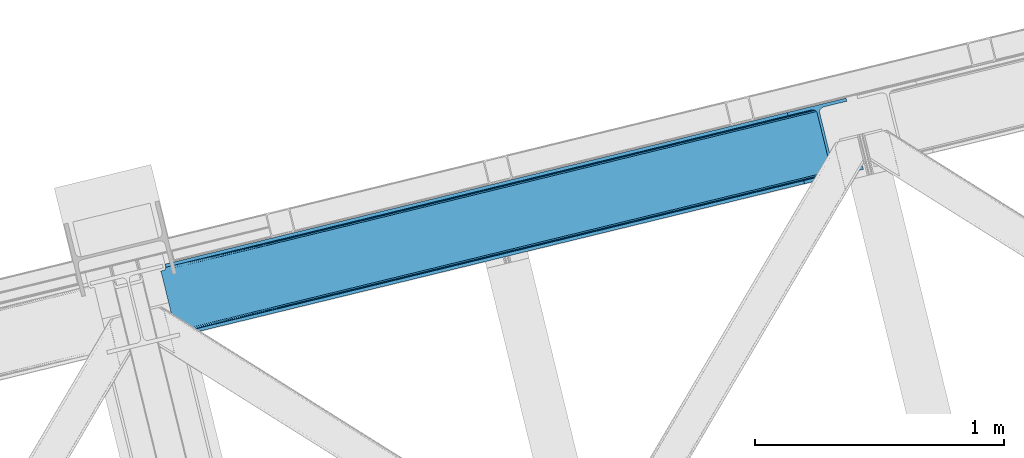
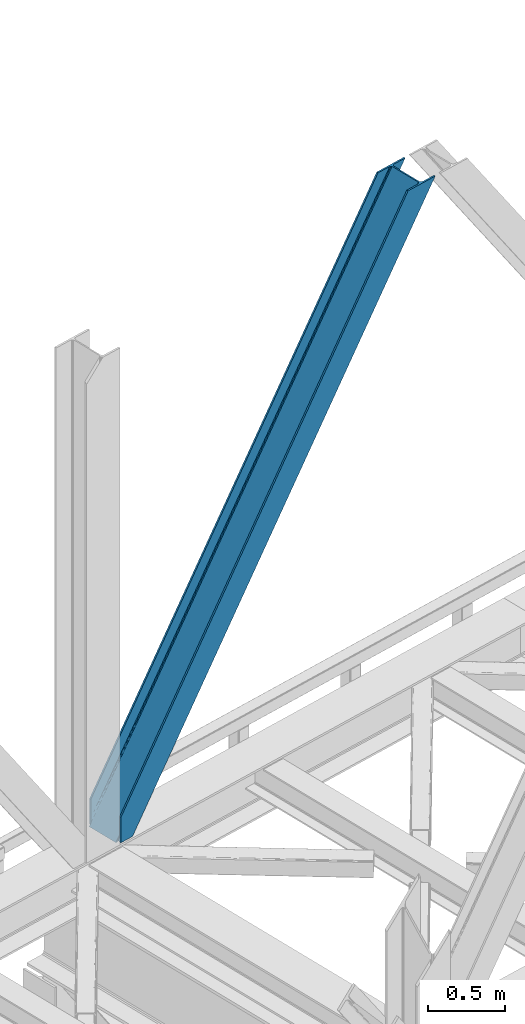
# One storey, part 32 of 93: 1 member.
"""IFC4 building model written with IfcOpenShell, lengths in millimetres."""

from ifc_helpers import new_model, entity, si_unit, converted_unit, derived_unit, direction, frame, origin, place, context, subcontext, project, spatial, triangles, type_object, element, save


model = new_model("IFC4")

# Units and contexts
model_context = context("Model", 3, precision=0.01, world=origin(), true_north=direction((6.12303176911189e-17, 1.0)))
plan_context = context("Plan", 3, precision=0.01, world=origin(), true_north=direction((6.12303176911189e-17, 1.0)))
body_context = subcontext(model_context, "Body", "Model", "MODEL_VIEW")
ifc_project = project(units=[si_unit("LENGTHUNIT", "METRE", prefix="MILLI"), si_unit("AREAUNIT", "SQUARE_METRE"), si_unit("VOLUMEUNIT", "CUBIC_METRE"), converted_unit("PLANEANGLEUNIT", "DEGREE", entity("IfcRatioMeasure", 0.0174532925199433), si_unit("PLANEANGLEUNIT", "RADIAN"), dimensions=[0, 0, 0, 0, 0, 0, 0]), si_unit("MASSUNIT", "GRAM", prefix="KILO"), derived_unit("MASSDENSITYUNIT", [(si_unit("MASSUNIT", "GRAM", prefix="KILO"), 1), (si_unit("LENGTHUNIT", "METRE"), -3)]), derived_unit("MOMENTOFINERTIAUNIT", [(si_unit("LENGTHUNIT", "METRE"), 4)]), si_unit("TIMEUNIT", "SECOND"), si_unit("FREQUENCYUNIT", "HERTZ"), si_unit("THERMODYNAMICTEMPERATUREUNIT", "DEGREE_CELSIUS"), derived_unit("THERMALTRANSMITTANCEUNIT", [(si_unit("MASSUNIT", "GRAM", prefix="KILO"), 1), (si_unit("THERMODYNAMICTEMPERATUREUNIT", "KELVIN"), -1), (si_unit("TIMEUNIT", "SECOND"), -3)]), derived_unit("VOLUMETRICFLOWRATEUNIT", [(si_unit("LENGTHUNIT", "METRE"), 3), (si_unit("TIMEUNIT", "SECOND"), -1)]), derived_unit("MASSFLOWRATEUNIT", [(si_unit("MASSUNIT", "GRAM", prefix="KILO"), 1), (si_unit("TIMEUNIT", "SECOND"), -1)]), derived_unit("ROTATIONALFREQUENCYUNIT", [(si_unit("TIMEUNIT", "SECOND"), -1)]), si_unit("ELECTRICCURRENTUNIT", "AMPERE"), si_unit("ELECTRICVOLTAGEUNIT", "VOLT"), si_unit("POWERUNIT", "WATT"), si_unit("FORCEUNIT", "NEWTON", prefix="KILO"), si_unit("ILLUMINANCEUNIT", "LUX"), si_unit("LUMINOUSFLUXUNIT", "LUMEN"), si_unit("LUMINOUSINTENSITYUNIT", "CANDELA"), derived_unit("USERDEFINED", [(si_unit("MASSUNIT", "GRAM", prefix="KILO"), -1), (si_unit("LENGTHUNIT", "METRE"), -2), (si_unit("TIMEUNIT", "SECOND"), 3), (si_unit("LUMINOUSFLUXUNIT", "LUMEN"), 1)]), derived_unit("LINEARVELOCITYUNIT", [(si_unit("LENGTHUNIT", "METRE"), 1), (si_unit("TIMEUNIT", "SECOND"), -1)]), si_unit("PRESSUREUNIT", "PASCAL"), derived_unit("USERDEFINED", [(si_unit("LENGTHUNIT", "METRE"), -2), (si_unit("MASSUNIT", "GRAM", prefix="KILO"), 1), (si_unit("TIMEUNIT", "SECOND"), -2)]), derived_unit("LINEARFORCEUNIT", [(si_unit("MASSUNIT", "GRAM", prefix="KILO"), 1), (si_unit("LENGTHUNIT", "METRE"), 1), (si_unit("TIMEUNIT", "SECOND"), -2), (si_unit("LENGTHUNIT", "METRE"), -1)]), derived_unit("PLANARFORCEUNIT", [(si_unit("MASSUNIT", "GRAM", prefix="KILO"), 1), (si_unit("LENGTHUNIT", "METRE"), 1), (si_unit("TIMEUNIT", "SECOND"), -2), (si_unit("LENGTHUNIT", "METRE"), -2)])], contexts=[model_context, plan_context])

# Site, building, storey
site_placement = place(None, origin())
site = spatial("IfcSite", under=ifc_project, at=site_placement, CompositionType="ELEMENT")
building_placement = place(site_placement, origin())
building = spatial("IfcBuilding", under=site, at=building_placement, CompositionType="ELEMENT")
storey_placement = place(building_placement, frame((0.0, 0.0, 15900.0)))
storey = spatial("IfcBuildingStorey", under=building, at=storey_placement, CompositionType="ELEMENT", Elevation=15900.0)

# Member
member_type = type_object("IfcMemberType", PredefinedType="BRACE")
member_placement = place(storey_placement, frame((-55077.6753295898, 7236.10715332031, 3694.99929199219)))
element("IfcMember", 1, at=member_placement, inside=storey, type_object=member_type, ObjectType="Steel Vertical Brace", PredefinedType="BRACE", context=body_context, shape_type="Tessellation", body=[
    triangles([(58.5731689453096, 24.8409255981442, 0.0), (60.4660766601592, 17.0687255859375, 0.0), (59.1126708984375, 17.8820480346676, 0.781347656247817), (58.9684936523408, 16.7042129516594, 1.0697021484375), (71.428198242189, 19.7406555175776, 19.5569458007813), (71.428198242189, 19.7406555175776, 0.0), (499.29045410156, 119.170051574707, 658.75048828125), (75.71630859375, 19.9243652343748, 26.4030395507798), (79.7486206054673, 18.4529434204096, 34.3676696777329), (501.02058105469, 125.602798461914, 656.525042724606), (81.3299194335923, 17.2873168945307, 38.5441589355469), (2694.2401977539, 660.223654174804, 3911.00081176758), (2694.23089599609, 667.310430908203, 3911.00081176758), (2268.13132324219, 563.444677734375, 3278.7231262207), (2268.67082519531, 556.485800170898, 3279.50447387695), (2691.01248779297, 653.425231933594, 3911.00081176758), (2266.94069824219, 550.053053283691, 3281.72759399414), (2685.03145751953, 647.951147460937, 3911.00081176758), (2263.20139160156, 545.12544708252, 3285.05529785156), (2677.20867919922, 644.635070800781, 3911.00081176758), (2258.02496337891, 542.454098510742, 3288.98063964843), (490.379370117189, 111.571678161621, 666.003533935545), (495.551147460938, 114.243026733398, 662.07819213867), (84.4413574218779, 12.6195785522459, 63.6403015136711), (83.9065063476592, 13.9003143310547, 51.2480346679658), (82.7484374999985, 15.426383972168, 45.5251281738274), (500.485729980472, 132.561676025391, 655.74602050781), (942.933142089845, 233.32354888916, 1312.27106323242), (942.398291015626, 240.282426452636, 1311.48971557617), (1384.845703125, 341.044299316406, 1968.01475830078), (1384.31085205078, 348.003176879883, 1967.23341064453), (1826.75826416015, 448.765049743653, 2623.75845336914), (1826.22341308594, 455.723927307129, 2622.97710571289), (941.203015136722, 226.891383361816, 1314.49418334961), (1383.11557617188, 334.611552429199, 1970.23787841797), (1825.02813720703, 442.332302856445, 2625.98389892578), (937.463708496092, 221.963777160644, 1317.82188720703), (1379.37626953125, 329.68452758789, 1973.56790771484), (1821.28883056641, 437.405278015137, 2629.3116027832), (932.291931152344, 219.291847229004, 1321.74955444336), (1374.2044921875, 327.013179016113, 1977.49324951172), (1816.11240234375, 434.733348083496, 2633.23694458008), (84.4413574218779, 12.6195785522459, 200.055230712889), (2585.27940673828, 622.225392150879, 3911.00081176758), (1329.12817382813, 574.374824523926, 1967.23341064453), (2639.05286865235, 893.682078552246, 3911.00081176758), (2212.95329589843, 789.816325378418, 3278.7231262207), (1771.04073486328, 682.095574951171, 2622.97710571289), (887.21561279297, 466.654074096679, 1311.48971557617), (445.303051757815, 358.933323669434, 655.74602050781), (3.39049072265334, 251.212573242187, 0.0), (2588.35828857422, 609.595349121094, 3911.00081176758), (84.7204101562529, 11.6585906982418, 200.120343017577), (87.5620971679673, 0.0, 200.120343017577), (87.5620971679673, 0.0, 0.0), (84.7204101562529, 11.6585906982418, 0.0), (72.8095092773438, 19.9854080200193, 0.0), (75.71630859375, 19.9243652343748, 3.35328369140552), (79.7486206054673, 18.4529434204096, 5.67639770507594), (77.6138671875015, 19.455207824707, 4.89272460937354), (81.3299194335923, 17.2873168945307, 5.12991943359157), (82.9112182617173, 15.5502136230461, 2.42078247070094), (83.5158325195298, 14.6316650390618, 0.0), (189.179150390628, 24.7705810546868, 0.0), (2824.8368774414, 667.240086364746, 3911.00081176758), (85.7296508789077, 14.7066604614256, 0.0), (94.1709960937515, 14.9915267944334, 0.0), (186.100268554685, 37.4006240844719, 0.0), (2821.75799560547, 679.870129394531, 3911.00081176758), (1408.54193115234, 335.383598327637, 1950.37164916992), (2299.97124023437, 552.67847442627, 3273.1420715332), (1854.2542602539, 444.031036376953, 2611.75686035156), (2729.82872314453, 657.461032104492, 3911.00081176758), (962.829602050784, 226.73616027832, 1288.98643798828), (517.112622070315, 118.088722229004, 627.598901367186), (501.20661621094, 125.647563171387, 637.077392578125), (72.1583862304688, 21.124291992187, 0.0), (505.704016113283, 120.733909606934, 634.854272460936), (498.481201171875, 132.073333740234, 637.858740234373), (511.289721679685, 118.079420471191, 631.526568603513), (2721.35947265625, 656.806420898437, 3911.00081176758), (2294.14368896485, 552.668591308594, 3277.06973876953), (2713.52739257812, 658.914431762695, 3911.00081176758), (2288.55798339844, 555.323661804199, 3280.39744262695), (2707.53240966797, 663.462991333007, 3911.00081176758), (2284.0605834961, 560.237896728516, 3282.62056274414), (2704.2814453125, 669.76028137207, 3911.00081176758), (2281.33516845703, 566.6630859375, 3283.40191040039), (68.6237182617188, 27.290776062011, 0.0), (957.006701660153, 226.726277160645, 1292.91177978515), (1402.71903076172, 335.373715209961, 1954.2969909668), (1848.43135986328, 444.02173461914, 2615.68220214844), (951.420996093751, 229.38134765625, 1296.23948364258), (1397.13332519531, 338.028785705566, 1957.62469482422), (1842.84565429688, 446.676223754883, 2619.01223144531), (946.9189453125, 234.295582580567, 1298.46260375976), (1392.63592529297, 342.943020629883, 1959.85014038086), (1838.34825439453, 451.589877319336, 2621.2353515625), (944.193530273435, 240.720771789551, 1299.24395141601), (1389.9105102539, 349.368209838867, 1960.63148803711), (1835.62283935547, 458.015647888184, 2622.01669921875), (1780.44481201172, 684.387295532227, 2622.01669921875), (1334.72783203125, 575.73985748291, 1960.63148803711), (2649.09876708985, 896.131929016113, 3911.00081176758), (2226.15714111328, 793.034733581543, 3283.40191040039), (889.015502929688, 467.092419433594, 1299.24395141601), (443.303173828128, 358.444981384278, 637.858740234373), (13.4410400390625, 253.662423706054, 0.0), (1.49758300781104, 258.985354614258, 0.0), (12.4597045898408, 261.657284545899, 0.0), (13.7433471679688, 260.764315795898, 0.0), (13.7991577148423, 262.075863647461, 0.0), (0.0, 258.620260620117, 1.0697021484375), (12.4597045898408, 261.657284545899, 19.5569458007813), (0.665075683595205, 257.638925170898, 0.781347656247817), (438.080236816408, 370.273329162597, 658.75048828125), (432.494531249999, 372.92781829834, 662.07819213867), (20.8498901367202, 272.585105895996, 51.2480346679658), (20.7243164062529, 270.661386108398, 44.4996093749978), (442.57763671875, 365.359675598144, 656.525042724606), (16.3524902343779, 263.467639160156, 26.4030395507798), (19.822045898436, 268.183049011231, 38.2720825195283), (19.254638671875, 266.629655456542, 34.3676696777329), (426.671630859375, 372.919097900391, 666.003533935545), (20.733618164064, 273.966998291015, 63.6403015136711), (2621.97484130859, 906.636520385742, 3911.00081176758), (2613.50559082031, 905.982490539551, 3911.00081176758), (2200.14477539063, 803.810820007324, 3285.05529785156), (2194.321875, 803.801518249512, 3288.98063964843), (2629.80227050781, 904.528509521484, 3911.00081176758), (2205.73048095703, 801.156330871582, 3281.72759399414), (2635.79725341797, 899.979949951172, 3911.00081176758), (2210.22788085938, 796.242095947266, 3279.50447387695), (874.407092285153, 480.648568725585, 1317.82188720703), (868.58419189453, 480.639266967773, 1321.74955444336), (1316.31965332032, 588.369319152832, 1973.56790771484), (1310.49675292968, 588.360017395019, 1977.49324951172), (1758.23221435547, 696.090069580078, 2629.3116027832), (1752.40931396485, 696.080767822265, 2633.23694458008), (879.992797851563, 477.994079589844, 1314.49418334961), (1321.90535888672, 585.714830017089, 1970.23787841797), (1763.81791992187, 693.435580444336, 2625.98389892578), (884.490197753905, 473.079844665527, 1312.27106323242), (1326.40275878906, 580.801176452636, 1968.01475830078), (1768.31531982422, 688.521345520019, 2623.75845336914), (2521.57166748047, 883.572811889649, 3911.00081176758), (20.733618164064, 273.966998291015, 200.055230712889), (16.3524902343779, 263.467639160156, 3.35328369140552), (19.254638671875, 266.629655456542, 5.67639770507594), (17.8221679687485, 264.760583496093, 4.89505004882813), (20.1197021484404, 268.390594482422, 5.12991943359157), (20.7243164062529, 270.661386108398, 2.42078247070094), (20.5429321289048, 274.949496459961, 0.0), (20.8405883789092, 271.75492401123, 0.0), (20.5429321289048, 274.949496459961, 200.120343017577), (22.8404663085967, 272.707191467285, 0.0), (448.233105468753, 376.764212036132, 631.526568603513), (444.493798828124, 371.837187194824, 634.854272460936), (30.4632568359375, 276.338946533203, 0.0), (442.763671875, 365.404440307617, 637.077392578125), (2649.08946533203, 903.219868469238, 3911.00081176758), (2225.61763916015, 799.994192504882, 3282.62056274414), (2652.32182617187, 910.017709350585, 3911.00081176758), (2227.35241699219, 806.426939392089, 3280.39744262695), (2658.30285644531, 915.491793823242, 3911.00081176758), (2231.08707275391, 811.353964233398, 3277.06973876953), (2666.12098388672, 918.808451843262, 3911.00081176758), (2236.26350097657, 814.025894165039, 3273.1420715332), (453.409533691403, 379.43556060791, 627.598901367186), (888.47600097656, 474.051878356933, 1298.46260375976), (1334.19298095703, 582.69931640625, 1959.85014038086), (1779.9053100586, 691.346754455566, 2621.2353515625), (890.210778808592, 480.48462524414, 1296.23948364258), (1335.92310791016, 589.132063293457, 1957.62469482422), (1781.63543701172, 697.779501342773, 2619.01223144531), (893.945434570313, 485.411650085449, 1292.91177978515), (1339.66241455078, 594.059088134765, 1954.2969909668), (1785.37474365234, 702.706526184082, 2615.68220214844), (899.12186279297, 488.08358001709, 1288.98643798828), (1344.83419189453, 596.731018066406, 1950.37164916992), (1790.551171875, 705.378456115723, 2611.75686035156), (2518.49278564453, 896.203436279297, 3911.00081176758), (17.7012451171904, 286.608087158203, 200.120343017577), (17.7012451171904, 286.608087158203, 0.0), (2754.97602539063, 953.847592163086, 3911.00081176758), (2758.05490722656, 941.217549133301, 3911.00081176758), (119.318298339844, 311.378086853028, 0.0), (122.392529296878, 298.748043823242, 0.0)], [[1, 2, 3], [4, 3, 2], [5, 4, 6], [2, 6, 4], [7, 8, 9], [10, 3, 5], [5, 7, 10], [5, 8, 7], [3, 4, 5], [9, 11, 7], [12, 13, 14], [14, 15, 12], [16, 12, 15], [15, 17, 16], [18, 16, 17], [17, 19, 18], [20, 18, 19], [19, 21, 20], [22, 23, 24], [25, 24, 23], [25, 7, 26], [25, 23, 7], [11, 26, 7], [10, 27, 1], [1, 3, 10], [28, 29, 27], [27, 10, 28], [30, 31, 28], [29, 28, 31], [32, 33, 31], [31, 30, 32], [15, 14, 33], [33, 32, 15], [34, 28, 7], [10, 7, 28], [35, 30, 34], [28, 34, 30], [36, 32, 30], [30, 35, 36], [17, 15, 36], [32, 36, 15], [37, 34, 23], [7, 23, 34], [38, 35, 34], [34, 37, 38], [39, 36, 38], [35, 38, 36], [19, 17, 39], [36, 39, 17], [40, 37, 23], [23, 22, 40], [41, 38, 40], [37, 40, 38], [42, 39, 41], [38, 41, 39], [21, 19, 42], [39, 42, 19], [41, 43, 44], [44, 21, 42], [21, 44, 20], [42, 41, 44], [43, 41, 40], [40, 22, 43], [24, 43, 22], [33, 45, 31], [13, 46, 47], [48, 14, 47], [45, 33, 48], [47, 14, 13], [48, 33, 14], [31, 49, 29], [49, 50, 27], [49, 31, 45], [51, 1, 50], [49, 27, 29], [50, 1, 27], [52, 53, 54], [52, 44, 53], [43, 53, 44], [55, 54, 53], [53, 56, 55], [5, 6, 57], [58, 8, 5], [59, 9, 8], [8, 58, 60], [61, 26, 11], [61, 11, 9], [9, 59, 61], [56, 26, 62], [56, 25, 26], [56, 53, 24], [43, 24, 53], [24, 25, 56], [62, 63, 56], [61, 62, 26], [8, 60, 59], [57, 58, 5], [52, 64, 65], [64, 52, 54], [55, 64, 54], [66, 67, 56], [64, 67, 68], [67, 64, 55], [55, 56, 67], [56, 63, 66], [69, 65, 68], [64, 68, 65], [70, 69, 68], [71, 69, 72], [71, 73, 69], [70, 72, 69], [68, 74, 70], [75, 74, 68], [68, 67, 75], [76, 60, 58], [76, 59, 60], [58, 77, 76], [58, 57, 77], [76, 78, 61], [61, 59, 76], [79, 76, 77], [80, 75, 67], [80, 62, 61], [80, 66, 62], [66, 63, 62], [61, 78, 80], [67, 66, 80], [81, 73, 71], [71, 82, 81], [83, 81, 82], [82, 84, 83], [85, 83, 84], [84, 86, 85], [87, 85, 86], [86, 88, 87], [77, 89, 79], [90, 74, 75], [75, 80, 90], [91, 70, 90], [74, 90, 70], [92, 72, 91], [70, 91, 72], [82, 71, 92], [72, 92, 71], [93, 90, 78], [80, 78, 90], [94, 91, 93], [90, 93, 91], [95, 92, 91], [91, 94, 95], [84, 82, 95], [92, 95, 82], [96, 93, 78], [78, 76, 96], [97, 94, 93], [93, 96, 97], [98, 95, 94], [94, 97, 98], [86, 84, 95], [95, 98, 86], [99, 96, 79], [76, 79, 96], [100, 97, 99], [96, 99, 97], [101, 98, 100], [97, 100, 98], [88, 86, 101], [98, 101, 86], [102, 100, 103], [104, 87, 88], [101, 105, 88], [100, 102, 101], [88, 105, 104], [101, 102, 105], [103, 99, 106], [99, 79, 107], [99, 103, 100], [89, 108, 79], [99, 107, 106], [79, 108, 107], [108, 109, 110], [51, 108, 89], [108, 51, 109], [89, 1, 51], [2, 89, 6], [89, 2, 1], [77, 6, 89], [108, 110, 111], [112, 111, 110], [57, 6, 77], [113, 114, 110], [110, 109, 113], [109, 51, 115], [115, 113, 109], [116, 117, 118], [118, 119, 116], [120, 121, 114], [114, 115, 120], [114, 113, 115], [120, 116, 122], [122, 123, 120], [123, 121, 120], [119, 122, 116], [117, 124, 125], [125, 118, 117], [126, 127, 128], [129, 128, 127], [130, 126, 131], [128, 131, 126], [132, 130, 133], [131, 133, 130], [46, 132, 47], [133, 47, 132], [134, 135, 117], [124, 117, 135], [136, 137, 135], [135, 134, 136], [138, 139, 137], [137, 136, 138], [128, 129, 139], [139, 138, 128], [140, 134, 116], [117, 116, 134], [141, 136, 140], [134, 140, 136], [142, 138, 136], [136, 141, 142], [131, 128, 138], [138, 142, 131], [143, 140, 116], [116, 120, 143], [144, 141, 140], [140, 143, 144], [145, 142, 144], [141, 144, 142], [133, 131, 142], [142, 145, 133], [50, 120, 51], [115, 51, 120], [49, 143, 50], [120, 50, 143], [45, 144, 143], [143, 49, 45], [48, 145, 45], [144, 45, 145], [47, 133, 48], [145, 48, 133], [146, 147, 137], [137, 139, 146], [139, 129, 146], [127, 146, 129], [135, 137, 147], [147, 125, 124], [124, 135, 147], [114, 148, 112], [112, 110, 114], [149, 150, 121], [121, 123, 149], [151, 149, 123], [123, 122, 151], [119, 152, 151], [153, 118, 125], [153, 154, 152], [152, 119, 153], [119, 118, 153], [155, 153, 125], [125, 147, 155], [122, 119, 151], [150, 148, 121], [114, 121, 148], [156, 157, 152], [157, 158, 151], [151, 152, 157], [157, 156, 159], [107, 108, 111], [160, 149, 151], [160, 111, 148], [148, 150, 160], [150, 149, 160], [111, 112, 148], [151, 158, 160], [111, 160, 107], [161, 104, 162], [105, 162, 104], [163, 161, 164], [162, 164, 161], [165, 163, 166], [164, 166, 163], [167, 165, 168], [166, 168, 165], [159, 169, 157], [152, 154, 156], [170, 106, 107], [107, 160, 170], [171, 103, 170], [106, 170, 103], [172, 102, 103], [103, 171, 172], [162, 105, 102], [102, 172, 162], [173, 170, 158], [160, 158, 170], [174, 171, 173], [170, 173, 171], [175, 172, 174], [171, 174, 172], [164, 162, 175], [172, 175, 162], [176, 173, 158], [158, 157, 176], [177, 174, 173], [173, 176, 177], [178, 175, 174], [174, 177, 178], [166, 164, 175], [175, 178, 166], [179, 176, 169], [157, 169, 176], [180, 177, 176], [176, 179, 180], [181, 178, 177], [177, 180, 181], [168, 166, 178], [178, 181, 168], [182, 155, 146], [155, 182, 183], [155, 147, 146], [153, 155, 184], [183, 184, 155], [46, 13, 104], [16, 18, 81], [20, 52, 65], [44, 52, 20], [18, 20, 73], [13, 12, 85], [12, 16, 83], [130, 165, 126], [182, 127, 185], [127, 126, 167], [182, 146, 127], [130, 132, 163], [132, 46, 161], [104, 13, 87], [73, 81, 18], [85, 12, 83], [81, 83, 16], [85, 87, 13], [65, 73, 20], [65, 69, 73], [167, 126, 165], [163, 132, 161], [104, 161, 46], [163, 165, 130], [167, 185, 127], [185, 167, 186], [159, 156, 153], [187, 159, 184], [159, 187, 188], [154, 153, 156], [153, 184, 159], [182, 187, 183], [182, 185, 187], [187, 184, 183], [186, 180, 188], [181, 186, 168], [186, 181, 180], [186, 167, 168], [179, 188, 180], [159, 188, 169], [179, 169, 188], [185, 186, 188], [188, 187, 185]]),
])

save(model, "model.ifc")
